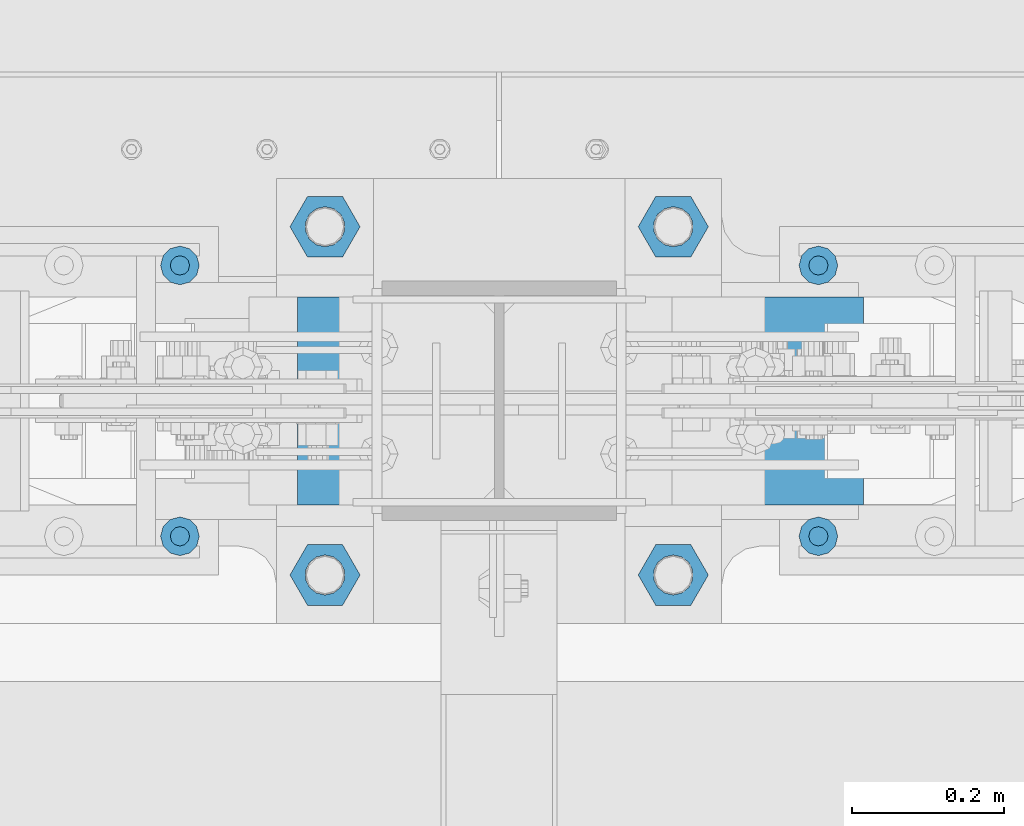
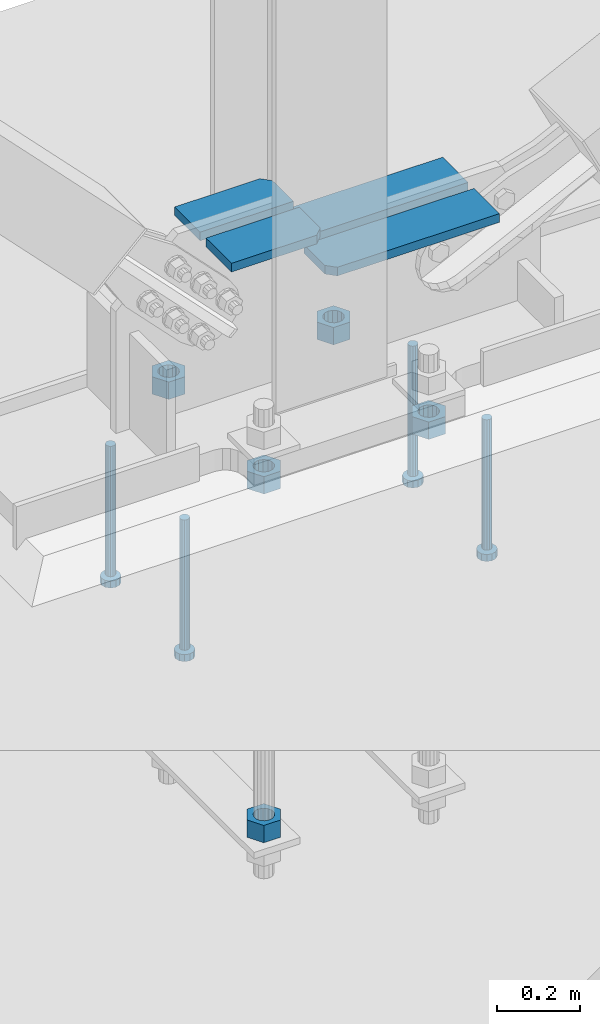
# One storey, part 886 of 1179: 13 beams, 7 elements without a shape of their own.
"""IFC2X3 building model written with IfcOpenShell, lengths in millimetres."""

from ifc_helpers import new_model, si_unit, frame, origin_with_axes, place, context, subcontext, project, spatial, faceted_brep, material, type_object, element, aggregate, save


model = new_model("IFC2X3")

# Units and contexts
model_context = context("Model", 3, precision=1e-05, world=origin_with_axes())
body_context = subcontext(model_context, "Body", "Model", "MODEL_VIEW")
ifc_project = project(units=[si_unit("LENGTHUNIT", "METRE", prefix="MILLI"), si_unit("AREAUNIT", "SQUARE_METRE"), si_unit("VOLUMEUNIT", "CUBIC_METRE"), si_unit("MASSUNIT", "GRAM", prefix="KILO"), si_unit("TIMEUNIT", "SECOND"), si_unit("PLANEANGLEUNIT", "RADIAN"), si_unit("SOLIDANGLEUNIT", "STERADIAN"), si_unit("THERMODYNAMICTEMPERATUREUNIT", "DEGREE_CELSIUS"), si_unit("LUMINOUSINTENSITYUNIT", "LUMEN")], contexts=[model_context])

# Site, building, storey
site_placement = place(None, origin_with_axes())
site = spatial("IfcSite", under=ifc_project, at=site_placement, CompositionType="ELEMENT")
building_placement = place(site_placement, origin_with_axes())
building = spatial("IfcBuilding", under=site, at=building_placement, Name="Undefined", CompositionType="ELEMENT")
storey_placement = place(building_placement, origin_with_axes())
storey = spatial("IfcBuildingStorey", under=building, at=storey_placement, Name="Undefined", CompositionType="ELEMENT", Elevation=0.0)

# Assembly, beam
assembly_1_placement = place(storey_placement, origin_with_axes())
assembly_1 = element("IfcElementAssembly", 1, at=assembly_1_placement, inside=storey, Name="PLATE", AssemblyPlace="NOTDEFINED", PredefinedType="RIGID_FRAME")
ifc_material_1 = material(Name="STEEL/A572-GR.50")
beam_type_1 = type_object("IfcBeamType", PredefinedType="NOTDEFINED")
beam_1_placement = place(assembly_1_placement, frame((8758.6086545226, 41274.2065, 143.742984862932), z_axis=(0.0, -1.0, 0.0), x_axis=(-1.0, 0.0, 0.0)))
beam_1 = element("IfcBeam", 2, at=beam_1_placement, type_object=beam_type_1, material=ifc_material_1, Name="PLATE", context=body_context, shape_type="Brep", body=[
    faceted_brep([(471.858654522599, -12.7, -38.8940000000002), (449.633654522599, -12.7, -61.1189999999988), (449.633654522599, 12.7, -61.1189999999988), (471.858654522599, 12.7, -38.8940000000002), (0.0, 12.7, -61.1189999999988), (0.0, 12.7, 61.1189999999988), (471.858654522599, 12.7, 61.1189999999988), (0.0, -12.7, 61.1189999999988), (471.858654522599, -12.7, 61.1189999999988), (0.0, -12.7, -61.1189999999988)], [[[0, 1, 2, 3]], [[4, 5, 6, 3, 2]], [[5, 7, 8, 6]], [[8, 7, 9, 1, 0]], [[9, 4, 2, 1]], [[6, 8, 0, 3]], [[9, 7, 5, 4]]]),
])
aggregate(assembly_1, [beam_1])

assembly_2_placement = place(storey_placement, origin_with_axes())
assembly_2 = element("IfcElementAssembly", 3, at=assembly_2_placement, inside=storey, Name="PLATE", AssemblyPlace="NOTDEFINED", PredefinedType="RIGID_FRAME")
beam_2_placement = place(assembly_2_placement, frame((8758.6086545226, 41123.3935, 143.742984862932), z_axis=(0.0, 1.0, 0.0), x_axis=(-1.0, 0.0, 0.0)))
beam_2 = element("IfcBeam", 4, at=beam_2_placement, type_object=beam_type_1, material=ifc_material_1, Name="PLATE", context=body_context, shape_type="Brep", body=[
    faceted_brep([(471.858654522599, -12.7, -38.8940000000002), (449.633654522599, -12.7, -61.1189999999988), (449.633654522599, 12.7, -61.1189999999988), (471.858654522599, 12.7, -38.8940000000002), (0.0, 12.7, -61.1189999999988), (0.0, 12.7, 61.1189999999988), (471.858654522599, 12.7, 61.1189999999988), (0.0, -12.7, 61.1189999999988), (471.858654522599, -12.7, 61.1189999999988), (0.0, -12.7, -61.1189999999988)], [[[0, 1, 2, 3]], [[4, 5, 6, 3, 2]], [[5, 7, 8, 6]], [[8, 7, 9, 1, 0]], [[9, 4, 2, 1]], [[6, 8, 0, 3]], [[9, 7, 5, 4]]]),
])
aggregate(assembly_2, [beam_2])

assembly_3_placement = place(storey_placement, origin_with_axes())
assembly_3 = element("IfcElementAssembly", 5, at=assembly_3_placement, inside=storey, Name="PLATE", AssemblyPlace="NOTDEFINED", PredefinedType="RIGID_FRAME")
beam_3_placement = place(assembly_3_placement, frame((8015.38676349688, 41274.2065, 258.098143425219), z_axis=(0.0, -1.0, 0.0), x_axis=(1.0, 0.0, 0.0)))
beam_3 = element("IfcBeam", 6, at=beam_3_placement, type_object=beam_type_1, material=ifc_material_1, Name="PLATE", context=body_context, shape_type="Brep", body=[
    faceted_brep([(236.438236021439, 12.7, -61.1189999999988), (258.663236021439, 12.7, -38.8940000000002), (258.663236021439, -12.7, -38.8940000000002), (236.438236021439, -12.7, -61.1189999999988), (0.0, 12.7, -61.1189999999988), (0.0, 12.7, 61.1189999999988), (258.663236021439, 12.7, 61.1189999999988), (0.0, -12.7, 61.1189999999988), (258.663236021439, -12.7, 61.1189999999988), (0.0, -12.7, -61.1189999999988)], [[[0, 1, 2, 3]], [[4, 5, 6, 1, 0]], [[5, 7, 8, 6]], [[8, 7, 9, 3, 2]], [[9, 4, 0, 3]], [[6, 8, 2, 1]], [[9, 7, 5, 4]]]),
])
aggregate(assembly_3, [beam_3])

assembly_4_placement = place(storey_placement, origin_with_axes())
assembly_4 = element("IfcElementAssembly", 7, at=assembly_4_placement, inside=storey, Name="PLATE", AssemblyPlace="NOTDEFINED", PredefinedType="RIGID_FRAME")
beam_4_placement = place(assembly_4_placement, frame((8015.38676349688, 41123.3935, 258.098143425219), z_axis=(0.0, 1.0, 0.0), x_axis=(1.0, 0.0, 0.0)))
beam_4 = element("IfcBeam", 8, at=beam_4_placement, type_object=beam_type_1, material=ifc_material_1, Name="PLATE", context=body_context, shape_type="Brep", body=[
    faceted_brep([(236.438236021439, 12.7, -61.1189999999988), (258.663236021439, 12.7, -38.8940000000002), (258.663236021439, -12.7, -38.8940000000002), (236.438236021439, -12.7, -61.1189999999988), (0.0, 12.7, -61.1189999999988), (0.0, 12.7, 61.1189999999988), (258.663236021439, 12.7, 61.1189999999988), (0.0, -12.7, 61.1189999999988), (258.663236021439, -12.7, 61.1189999999988), (0.0, -12.7, -61.1189999999988)], [[[0, 1, 2, 3]], [[4, 5, 6, 1, 0]], [[5, 7, 8, 6]], [[8, 7, 9, 3, 2]], [[9, 4, 0, 3]], [[6, 8, 2, 1]], [[9, 7, 5, 4]]]),
])
aggregate(assembly_4, [beam_4])

# Assembly, beams
assembly_5_placement = place(storey_placement, origin_with_axes())
assembly_5 = element("IfcElementAssembly", 9, at=assembly_5_placement, inside=storey, Name="TEMPLATE", AssemblyPlace="NOTDEFINED", PredefinedType="RIGID_FRAME")
ifc_material_2 = material(Name="STEEL/A36")
beam_type_2 = type_object("IfcBeamType", Name="2_HEAVY_HEX_NUT", PredefinedType="NOTDEFINED")
beam_5_placement = place(assembly_5_placement, frame((8051.79998779297, 40970.2, -279.4), z_axis=(0.0, -1.0, 0.0), x_axis=(0.0, 0.0, -1.0)))
beam_5 = element("IfcBeam", 10, at=beam_5_placement, type_object=beam_type_2, material=ifc_material_2, Name="NUT", ObjectType="2_HEAVY_HEX_NUT", context=body_context, shape_type="Brep", body=[
    faceted_brep([(0.0, -46.0369987487793, 9.09494701772928e-13), (0.0, -23.0184993743896, -39.869213104248), (50.7999999999993, -23.0184993743896, -39.869213104248), (50.7999999999993, -46.0369987487793, 9.09494701772928e-13), (0.0, 23.0184993743896, -39.869213104248), (50.7999999999993, 23.0184993743896, -39.869213104248), (0.0, 46.0369987487793, -9.09494701772928e-13), (50.7999999999993, 46.0369987487793, -9.09494701772928e-13), (0.0, 23.0184993743896, 39.869213104248), (50.7999999999993, 23.0184993743896, 39.869213104248), (0.0, -23.0184993743896, 39.869213104248), (50.7999999999993, -23.0184993743896, 39.869213104248), (0.0, 0.0, 26.1940002441406), (0.0, 11.3650617044477, 23.5999013092769), (50.7999999999993, 11.3650617044477, 23.5999013092769), (50.7999999999993, 0.0, 26.1940002441406), (0.0, 20.4791109456419, 16.3316083006703), (50.7999999999993, 20.4791109456419, 16.3316083006703), (0.0, 25.5370200498364, 5.82867859874477), (50.7999999999993, 25.5370200498364, 5.82867859874477), (0.0, 25.5370200498364, -5.82867859874477), (50.7999999999993, 25.5370200498364, -5.82867859874477), (0.0, 20.4791109456419, -16.3316083006703), (50.7999999999993, 20.4791109456419, -16.3316083006703), (0.0, 11.365061704455, -23.5999013092769), (50.7999999999993, 11.365061704455, -23.5999013092769), (0.0, 0.0, -26.1940002441406), (50.7999999999993, 0.0, -26.1940002441406), (0.0, -11.3650617044477, -23.5999013092769), (50.7999999999993, -11.3650617044477, -23.5999013092769), (0.0, -20.4791109456419, -16.3316083006703), (50.7999999999993, -20.4791109456419, -16.3316083006703), (0.0, -25.5370200498364, -5.82867859874477), (50.7999999999993, -25.5370200498364, -5.82867859874477), (0.0, -25.5370200498364, 5.82867859874477), (50.7999999999993, -25.5370200498364, 5.82867859874477), (0.0, -20.4791109456419, 16.3316083006703), (50.7999999999993, -20.4791109456419, 16.3316083006703), (0.0, -11.365061704455, 23.5999013092769), (50.7999999999993, -11.365061704455, 23.5999013092769)], [[[0, 1, 2, 3]], [[1, 4, 5, 2]], [[4, 6, 7, 5]], [[6, 8, 9, 7]], [[8, 10, 11, 9]], [[10, 0, 3, 11]], [[12, 13, 14, 15]], [[13, 16, 17, 14]], [[16, 18, 19, 17]], [[18, 20, 21, 19]], [[20, 22, 23, 21]], [[22, 24, 25, 23]], [[24, 26, 27, 25]], [[26, 28, 29, 27]], [[28, 30, 31, 29]], [[30, 32, 33, 31]], [[32, 34, 35, 33]], [[34, 36, 37, 35]], [[36, 38, 39, 37]], [[38, 12, 15, 39]], [[5, 7, 9, 11, 3, 2], [17, 19, 21, 23, 25, 27, 29, 31, 33, 35, 37, 39, 15, 14]], [[10, 8, 6, 4, 1, 0], [38, 36, 34, 32, 30, 28, 26, 24, 22, 20, 18, 16, 13, 12]]]),
])
beam_6_placement = place(assembly_5_placement, frame((8508.99998779298, 40970.2, -279.4), z_axis=(0.0, 1.0, 0.0), x_axis=(0.0, 0.0, -1.0)))
beam_6 = element("IfcBeam", 11, at=beam_6_placement, type_object=beam_type_2, material=ifc_material_2, Name="NUT", ObjectType="2_HEAVY_HEX_NUT", context=body_context, shape_type="Brep", body=[
    faceted_brep([(0.0, -46.0369987487793, 9.09494701772928e-13), (0.0, -23.0184993743896, -39.869213104248), (50.7999999999993, -23.0184993743896, -39.869213104248), (50.7999999999993, -46.0369987487793, 9.09494701772928e-13), (0.0, 23.0184993743896, -39.869213104248), (50.7999999999993, 23.0184993743896, -39.869213104248), (0.0, 46.0369987487793, -9.09494701772928e-13), (50.7999999999993, 46.0369987487793, -9.09494701772928e-13), (0.0, 23.0184993743896, 39.869213104248), (50.7999999999993, 23.0184993743896, 39.869213104248), (0.0, -23.0184993743896, 39.869213104248), (50.7999999999993, -23.0184993743896, 39.869213104248), (0.0, 0.0, 26.1940002441406), (0.0, 11.3650617044477, 23.5999013092769), (50.7999999999993, 11.3650617044477, 23.5999013092769), (50.7999999999993, 0.0, 26.1940002441406), (0.0, 20.4791109456419, 16.3316083006703), (50.7999999999993, 20.4791109456419, 16.3316083006703), (0.0, 25.5370200498364, 5.82867859874477), (50.7999999999993, 25.5370200498364, 5.82867859874477), (0.0, 25.5370200498364, -5.82867859874477), (50.7999999999993, 25.5370200498364, -5.82867859874477), (0.0, 20.4791109456419, -16.3316083006703), (50.7999999999993, 20.4791109456419, -16.3316083006703), (0.0, 11.365061704455, -23.5999013092769), (50.7999999999993, 11.365061704455, -23.5999013092769), (0.0, 0.0, -26.1940002441406), (50.7999999999993, 0.0, -26.1940002441406), (0.0, -11.3650617044477, -23.5999013092769), (50.7999999999993, -11.3650617044477, -23.5999013092769), (0.0, -20.4791109456419, -16.3316083006703), (50.7999999999993, -20.4791109456419, -16.3316083006703), (0.0, -25.5370200498364, -5.82867859874477), (50.7999999999993, -25.5370200498364, -5.82867859874477), (0.0, -25.5370200498364, 5.82867859874477), (50.7999999999993, -25.5370200498364, 5.82867859874477), (0.0, -20.4791109456419, 16.3316083006703), (50.7999999999993, -20.4791109456419, 16.3316083006703), (0.0, -11.365061704455, 23.5999013092769), (50.7999999999993, -11.365061704455, 23.5999013092769)], [[[0, 1, 2, 3]], [[1, 4, 5, 2]], [[4, 6, 7, 5]], [[6, 8, 9, 7]], [[8, 10, 11, 9]], [[10, 0, 3, 11]], [[12, 13, 14, 15]], [[13, 16, 17, 14]], [[16, 18, 19, 17]], [[18, 20, 21, 19]], [[20, 22, 23, 21]], [[22, 24, 25, 23]], [[24, 26, 27, 25]], [[26, 28, 29, 27]], [[28, 30, 31, 29]], [[30, 32, 33, 31]], [[32, 34, 35, 33]], [[34, 36, 37, 35]], [[36, 38, 39, 37]], [[38, 12, 15, 39]], [[5, 7, 9, 11, 3, 2], [17, 19, 21, 23, 25, 27, 29, 31, 33, 35, 37, 39, 15, 14]], [[10, 8, 6, 4, 1, 0], [38, 36, 34, 32, 30, 28, 26, 24, 22, 20, 18, 16, 13, 12]]]),
])
beam_7_placement = place(assembly_5_placement, frame((8051.79998779297, 41427.4, -279.4), z_axis=(0.0, -1.0, 0.0), x_axis=(0.0, 0.0, -1.0)))
beam_7 = element("IfcBeam", 12, at=beam_7_placement, type_object=beam_type_2, material=ifc_material_2, Name="NUT", ObjectType="2_HEAVY_HEX_NUT", context=body_context, shape_type="Brep", body=[
    faceted_brep([(0.0, -46.0369987487793, 9.09494701772928e-13), (0.0, -23.0184993743896, -39.869213104248), (50.7999999999993, -23.0184993743896, -39.869213104248), (50.7999999999993, -46.0369987487793, 9.09494701772928e-13), (0.0, 23.0184993743896, -39.869213104248), (50.7999999999993, 23.0184993743896, -39.869213104248), (0.0, 46.0369987487793, -9.09494701772928e-13), (50.7999999999993, 46.0369987487793, -9.09494701772928e-13), (0.0, 23.0184993743896, 39.869213104248), (50.7999999999993, 23.0184993743896, 39.869213104248), (0.0, -23.0184993743896, 39.869213104248), (50.7999999999993, -23.0184993743896, 39.869213104248), (0.0, 0.0, 26.1940002441406), (0.0, 11.3650617044477, 23.5999013092769), (50.7999999999993, 11.3650617044477, 23.5999013092769), (50.7999999999993, 0.0, 26.1940002441406), (0.0, 20.4791109456419, 16.3316083006703), (50.7999999999993, 20.4791109456419, 16.3316083006703), (0.0, 25.5370200498364, 5.82867859874477), (50.7999999999993, 25.5370200498364, 5.82867859874477), (0.0, 25.5370200498364, -5.82867859874477), (50.7999999999993, 25.5370200498364, -5.82867859874477), (0.0, 20.4791109456419, -16.3316083006703), (50.7999999999993, 20.4791109456419, -16.3316083006703), (0.0, 11.365061704455, -23.5999013092769), (50.7999999999993, 11.365061704455, -23.5999013092769), (0.0, 0.0, -26.1940002441406), (50.7999999999993, 0.0, -26.1940002441406), (0.0, -11.3650617044477, -23.5999013092769), (50.7999999999993, -11.3650617044477, -23.5999013092769), (0.0, -20.4791109456419, -16.3316083006703), (50.7999999999993, -20.4791109456419, -16.3316083006703), (0.0, -25.5370200498364, -5.82867859874477), (50.7999999999993, -25.5370200498364, -5.82867859874477), (0.0, -25.5370200498364, 5.82867859874477), (50.7999999999993, -25.5370200498364, 5.82867859874477), (0.0, -20.4791109456419, 16.3316083006703), (50.7999999999993, -20.4791109456419, 16.3316083006703), (0.0, -11.365061704455, 23.5999013092769), (50.7999999999993, -11.365061704455, 23.5999013092769)], [[[0, 1, 2, 3]], [[1, 4, 5, 2]], [[4, 6, 7, 5]], [[6, 8, 9, 7]], [[8, 10, 11, 9]], [[10, 0, 3, 11]], [[12, 13, 14, 15]], [[13, 16, 17, 14]], [[16, 18, 19, 17]], [[18, 20, 21, 19]], [[20, 22, 23, 21]], [[22, 24, 25, 23]], [[24, 26, 27, 25]], [[26, 28, 29, 27]], [[28, 30, 31, 29]], [[30, 32, 33, 31]], [[32, 34, 35, 33]], [[34, 36, 37, 35]], [[36, 38, 39, 37]], [[38, 12, 15, 39]], [[5, 7, 9, 11, 3, 2], [17, 19, 21, 23, 25, 27, 29, 31, 33, 35, 37, 39, 15, 14]], [[10, 8, 6, 4, 1, 0], [38, 36, 34, 32, 30, 28, 26, 24, 22, 20, 18, 16, 13, 12]]]),
])
beam_8_placement = place(assembly_5_placement, frame((8508.99998779298, 41427.4, -279.4), z_axis=(0.0, 1.0, 0.0), x_axis=(0.0, 0.0, -1.0)))
beam_8 = element("IfcBeam", 13, at=beam_8_placement, type_object=beam_type_2, material=ifc_material_2, Name="NUT", ObjectType="2_HEAVY_HEX_NUT", context=body_context, shape_type="Brep", body=[
    faceted_brep([(0.0, -46.0369987487793, 9.09494701772928e-13), (0.0, -23.0184993743896, -39.869213104248), (50.7999999999993, -23.0184993743896, -39.869213104248), (50.7999999999993, -46.0369987487793, 9.09494701772928e-13), (0.0, 23.0184993743896, -39.869213104248), (50.7999999999993, 23.0184993743896, -39.869213104248), (0.0, 46.0369987487793, -9.09494701772928e-13), (50.7999999999993, 46.0369987487793, -9.09494701772928e-13), (0.0, 23.0184993743896, 39.869213104248), (50.7999999999993, 23.0184993743896, 39.869213104248), (0.0, -23.0184993743896, 39.869213104248), (50.7999999999993, -23.0184993743896, 39.869213104248), (0.0, 0.0, 26.1940002441406), (0.0, 11.3650617044477, 23.5999013092769), (50.7999999999993, 11.3650617044477, 23.5999013092769), (50.7999999999993, 0.0, 26.1940002441406), (0.0, 20.4791109456419, 16.3316083006703), (50.7999999999993, 20.4791109456419, 16.3316083006703), (0.0, 25.5370200498364, 5.82867859874477), (50.7999999999993, 25.5370200498364, 5.82867859874477), (0.0, 25.5370200498364, -5.82867859874477), (50.7999999999993, 25.5370200498364, -5.82867859874477), (0.0, 20.4791109456419, -16.3316083006703), (50.7999999999993, 20.4791109456419, -16.3316083006703), (0.0, 11.365061704455, -23.5999013092769), (50.7999999999993, 11.365061704455, -23.5999013092769), (0.0, 0.0, -26.1940002441406), (50.7999999999993, 0.0, -26.1940002441406), (0.0, -11.3650617044477, -23.5999013092769), (50.7999999999993, -11.3650617044477, -23.5999013092769), (0.0, -20.4791109456419, -16.3316083006703), (50.7999999999993, -20.4791109456419, -16.3316083006703), (0.0, -25.5370200498364, -5.82867859874477), (50.7999999999993, -25.5370200498364, -5.82867859874477), (0.0, -25.5370200498364, 5.82867859874477), (50.7999999999993, -25.5370200498364, 5.82867859874477), (0.0, -20.4791109456419, 16.3316083006703), (50.7999999999993, -20.4791109456419, 16.3316083006703), (0.0, -11.365061704455, 23.5999013092769), (50.7999999999993, -11.365061704455, 23.5999013092769)], [[[0, 1, 2, 3]], [[1, 4, 5, 2]], [[4, 6, 7, 5]], [[6, 8, 9, 7]], [[8, 10, 11, 9]], [[10, 0, 3, 11]], [[12, 13, 14, 15]], [[13, 16, 17, 14]], [[16, 18, 19, 17]], [[18, 20, 21, 19]], [[20, 22, 23, 21]], [[22, 24, 25, 23]], [[24, 26, 27, 25]], [[26, 28, 29, 27]], [[28, 30, 31, 29]], [[30, 32, 33, 31]], [[32, 34, 35, 33]], [[34, 36, 37, 35]], [[36, 38, 39, 37]], [[38, 12, 15, 39]], [[5, 7, 9, 11, 3, 2], [17, 19, 21, 23, 25, 27, 29, 31, 33, 35, 37, 39, 15, 14]], [[10, 8, 6, 4, 1, 0], [38, 36, 34, 32, 30, 28, 26, 24, 22, 20, 18, 16, 13, 12]]]),
])
beam_9_placement = place(assembly_5_placement, frame((8051.80000000002, 40970.2, -1301.75), z_axis=(0.0, -1.0, 0.0), x_axis=(0.0, 0.0, -1.0)))
beam_9 = element("IfcBeam", 14, at=beam_9_placement, type_object=beam_type_2, material=ifc_material_2, Name="NUT", ObjectType="2_HEAVY_HEX_NUT", context=body_context, shape_type="Brep", body=[
    faceted_brep([(0.0, -46.0369987487793, 9.09494701772928e-13), (0.0, -23.0184993743896, -39.869213104248), (50.7999999999993, -23.0184993743896, -39.869213104248), (50.7999999999993, -46.0369987487793, 9.09494701772928e-13), (0.0, 23.0184993743896, -39.869213104248), (50.7999999999993, 23.0184993743896, -39.869213104248), (0.0, 46.0369987487793, -9.09494701772928e-13), (50.7999999999993, 46.0369987487793, -9.09494701772928e-13), (0.0, 23.0184993743896, 39.869213104248), (50.7999999999993, 23.0184993743896, 39.869213104248), (0.0, -23.0184993743896, 39.869213104248), (50.7999999999993, -23.0184993743896, 39.869213104248), (0.0, 0.0, 26.1940002441406), (0.0, 11.3650617044477, 23.5999013092769), (50.7999999999993, 11.3650617044477, 23.5999013092769), (50.7999999999993, 0.0, 26.1940002441406), (0.0, 20.4791109456419, 16.3316083006703), (50.7999999999993, 20.4791109456419, 16.3316083006703), (0.0, 25.5370200498364, 5.82867859874477), (50.7999999999993, 25.5370200498364, 5.82867859874477), (0.0, 25.5370200498364, -5.82867859874477), (50.7999999999993, 25.5370200498364, -5.82867859874477), (0.0, 20.4791109456419, -16.3316083006703), (50.7999999999993, 20.4791109456419, -16.3316083006703), (0.0, 11.365061704455, -23.5999013092769), (50.7999999999993, 11.365061704455, -23.5999013092769), (0.0, 0.0, -26.1940002441406), (50.7999999999993, 0.0, -26.1940002441406), (0.0, -11.3650617044477, -23.5999013092769), (50.7999999999993, -11.3650617044477, -23.5999013092769), (0.0, -20.4791109456419, -16.3316083006703), (50.7999999999993, -20.4791109456419, -16.3316083006703), (0.0, -25.5370200498364, -5.82867859874477), (50.7999999999993, -25.5370200498364, -5.82867859874477), (0.0, -25.5370200498364, 5.82867859874477), (50.7999999999993, -25.5370200498364, 5.82867859874477), (0.0, -20.4791109456419, 16.3316083006703), (50.7999999999993, -20.4791109456419, 16.3316083006703), (0.0, -11.365061704455, 23.5999013092769), (50.7999999999993, -11.365061704455, 23.5999013092769)], [[[0, 1, 2, 3]], [[1, 4, 5, 2]], [[4, 6, 7, 5]], [[6, 8, 9, 7]], [[8, 10, 11, 9]], [[10, 0, 3, 11]], [[12, 13, 14, 15]], [[13, 16, 17, 14]], [[16, 18, 19, 17]], [[18, 20, 21, 19]], [[20, 22, 23, 21]], [[22, 24, 25, 23]], [[24, 26, 27, 25]], [[26, 28, 29, 27]], [[28, 30, 31, 29]], [[30, 32, 33, 31]], [[32, 34, 35, 33]], [[34, 36, 37, 35]], [[36, 38, 39, 37]], [[38, 12, 15, 39]], [[5, 7, 9, 11, 3, 2], [17, 19, 21, 23, 25, 27, 29, 31, 33, 35, 37, 39, 15, 14]], [[10, 8, 6, 4, 1, 0], [38, 36, 34, 32, 30, 28, 26, 24, 22, 20, 18, 16, 13, 12]]]),
])
aggregate(assembly_5, [beam_5, beam_6, beam_7, beam_8, beam_9])

assembly_6_placement = place(storey_placement, origin_with_axes())
assembly_6 = element("IfcElementAssembly", 15, at=assembly_6_placement, inside=storey, Name="EMBED_PLATE", AssemblyPlace="NOTDEFINED", PredefinedType="RIGID_FRAME")
ifc_material_3 = material(Name="STEEL/A108")
beam_type_3 = type_object("IfcBeamType", Name="STUD_1-DIA", PredefinedType="NOTDEFINED")
beam_10_placement = place(assembly_6_placement, frame((8699.5, 41376.6, -393.7), z_axis=(1.0, 0.0, 0.0), x_axis=(0.0, 0.0, -1.0)))
beam_10 = element("IfcBeam", 16, at=beam_10_placement, type_object=beam_type_3, material=ifc_material_3, Name="STUD", ObjectType="STUD_1-DIA", context=body_context, shape_type="Brep", body=[
    faceted_brep([(0.0, -12.7, 0.0), (0.0, -11.0, -6.34999990463257), (382.016, -11.0, -6.34999990463257), (382.016, -12.6999998092651, 0.0), (0.0, -6.34999990463257, -11.0), (382.016, -6.34999990463257, -11.0), (0.0, 0.0, -12.6999998092651), (382.016, 0.0, -12.6999998092651), (0.0, 6.34999990463257, -11.0), (382.016, 6.34999990463257, -11.0), (0.0, 11.0, -6.34999990463257), (382.016, 11.0, -6.34999990463257), (0.0, 12.7, 0.0), (382.016, 12.6999998092651, 0.0), (0.0, 11.0, 6.34999990463257), (382.016, 11.0, 6.34999990463257), (0.0, 6.34999990463257, 11.0), (382.016, 6.34999990463257, 11.0), (0.0, 0.0, 12.6999998092651), (382.016, 0.0, 12.6999998092651), (0.0, -6.34999990463257, 11.0), (382.016, -6.34999990463257, 11.0), (0.0, -11.0, 6.34999990463257), (382.016, -11.0, 6.34999990463257), (386.08, -22.0, -12.6999998092651), (386.08, -25.3999996185303, 0.0), (386.08, -12.6999998092651, -22.0), (386.08, 0.0, -25.3999996185303), (386.08, 12.6999998092651, -22.0), (386.08, 22.0, -12.6999998092651), (386.08, 25.3999996185303, 0.0), (386.08, 22.0, 12.6999998092651), (386.08, 12.6999998092651, 22.0), (386.08, 0.0, 25.3999996185303), (386.08, -12.6999998092651, 22.0), (386.08, -22.0, 12.6999998092651), (406.4, -22.0, -12.6999998092651), (406.4, -25.3999996185303, 0.0), (406.4, -12.6999998092651, -22.0), (406.4, 0.0, -25.3999996185303), (406.4, 12.6999998092651, -22.0), (406.4, 22.0, -12.6999998092651), (406.4, 25.3999996185303, 0.0), (406.4, 22.0, 12.6999998092651), (406.4, 12.6999998092651, 22.0), (406.4, 0.0, 25.3999996185303), (406.4, -12.6999998092651, 22.0), (406.4, -22.0, 12.6999998092651)], [[[0, 1, 2, 3]], [[1, 4, 5, 2]], [[4, 6, 7, 5]], [[6, 8, 9, 7]], [[8, 10, 11, 9]], [[10, 12, 13, 11]], [[12, 14, 15, 13]], [[14, 16, 17, 15]], [[16, 18, 19, 17]], [[18, 20, 21, 19]], [[20, 22, 23, 21]], [[22, 0, 3, 23]], [[22, 20, 18, 16, 14, 12, 10, 8, 6, 4, 1, 0]], [[3, 2, 24, 25]], [[2, 5, 26, 24]], [[5, 7, 27, 26]], [[7, 9, 28, 27]], [[9, 11, 29, 28]], [[11, 13, 30, 29]], [[13, 15, 31, 30]], [[15, 17, 32, 31]], [[17, 19, 33, 32]], [[19, 21, 34, 33]], [[21, 23, 35, 34]], [[23, 3, 25, 35]], [[25, 24, 36, 37]], [[24, 26, 38, 36]], [[26, 27, 39, 38]], [[27, 28, 40, 39]], [[28, 29, 41, 40]], [[29, 30, 42, 41]], [[30, 31, 43, 42]], [[31, 32, 44, 43]], [[32, 33, 45, 44]], [[33, 34, 46, 45]], [[34, 35, 47, 46]], [[35, 25, 37, 47]], [[38, 39, 40, 41, 42, 43, 44, 45, 46, 47, 37, 36]]]),
])
beam_11_placement = place(assembly_6_placement, frame((8699.5, 41021.0, -393.7), z_axis=(1.0, 0.0, 0.0), x_axis=(0.0, 0.0, -1.0)))
beam_11 = element("IfcBeam", 17, at=beam_11_placement, type_object=beam_type_3, material=ifc_material_3, Name="STUD", ObjectType="STUD_1-DIA", context=body_context, shape_type="Brep", body=[
    faceted_brep([(0.0, -12.7, 0.0), (0.0, -11.0, -6.34999990463257), (382.016, -11.0, -6.34999990463257), (382.016, -12.6999998092651, 0.0), (0.0, -6.34999990463257, -11.0), (382.016, -6.34999990463257, -11.0), (0.0, 0.0, -12.6999998092651), (382.016, 0.0, -12.6999998092651), (0.0, 6.34999990463257, -11.0), (382.016, 6.34999990463257, -11.0), (0.0, 11.0, -6.34999990463257), (382.016, 11.0, -6.34999990463257), (0.0, 12.7, 0.0), (382.016, 12.6999998092651, 0.0), (0.0, 11.0, 6.34999990463257), (382.016, 11.0, 6.34999990463257), (0.0, 6.34999990463257, 11.0), (382.016, 6.34999990463257, 11.0), (0.0, 0.0, 12.6999998092651), (382.016, 0.0, 12.6999998092651), (0.0, -6.34999990463257, 11.0), (382.016, -6.34999990463257, 11.0), (0.0, -11.0, 6.34999990463257), (382.016, -11.0, 6.34999990463257), (386.08, -22.0, -12.6999998092651), (386.08, -25.3999996185303, 0.0), (386.08, -12.6999998092651, -22.0), (386.08, 0.0, -25.3999996185303), (386.08, 12.6999998092651, -22.0), (386.08, 22.0, -12.6999998092651), (386.08, 25.3999996185303, 0.0), (386.08, 22.0, 12.6999998092651), (386.08, 12.6999998092651, 22.0), (386.08, 0.0, 25.3999996185303), (386.08, -12.6999998092651, 22.0), (386.08, -22.0, 12.6999998092651), (406.4, -22.0, -12.6999998092651), (406.4, -25.3999996185303, 0.0), (406.4, -12.6999998092651, -22.0), (406.4, 0.0, -25.3999996185303), (406.4, 12.6999998092651, -22.0), (406.4, 22.0, -12.6999998092651), (406.4, 25.3999996185303, 0.0), (406.4, 22.0, 12.6999998092651), (406.4, 12.6999998092651, 22.0), (406.4, 0.0, 25.3999996185303), (406.4, -12.6999998092651, 22.0), (406.4, -22.0, 12.6999998092651)], [[[0, 1, 2, 3]], [[1, 4, 5, 2]], [[4, 6, 7, 5]], [[6, 8, 9, 7]], [[8, 10, 11, 9]], [[10, 12, 13, 11]], [[12, 14, 15, 13]], [[14, 16, 17, 15]], [[16, 18, 19, 17]], [[18, 20, 21, 19]], [[20, 22, 23, 21]], [[22, 0, 3, 23]], [[22, 20, 18, 16, 14, 12, 10, 8, 6, 4, 1, 0]], [[3, 2, 24, 25]], [[2, 5, 26, 24]], [[5, 7, 27, 26]], [[7, 9, 28, 27]], [[9, 11, 29, 28]], [[11, 13, 30, 29]], [[13, 15, 31, 30]], [[15, 17, 32, 31]], [[17, 19, 33, 32]], [[19, 21, 34, 33]], [[21, 23, 35, 34]], [[23, 3, 25, 35]], [[25, 24, 36, 37]], [[24, 26, 38, 36]], [[26, 27, 39, 38]], [[27, 28, 40, 39]], [[28, 29, 41, 40]], [[29, 30, 42, 41]], [[30, 31, 43, 42]], [[31, 32, 44, 43]], [[32, 33, 45, 44]], [[33, 34, 46, 45]], [[34, 35, 47, 46]], [[35, 25, 37, 47]], [[38, 39, 40, 41, 42, 43, 44, 45, 46, 47, 37, 36]]]),
])
aggregate(assembly_6, [beam_10, beam_11])

assembly_7_placement = place(storey_placement, origin_with_axes())
assembly_7 = element("IfcElementAssembly", 18, at=assembly_7_placement, inside=storey, Name="EMBED_PLATE", AssemblyPlace="NOTDEFINED", PredefinedType="RIGID_FRAME")
beam_12_placement = place(assembly_7_placement, frame((7861.30000000002, 41376.6, -393.7), z_axis=(1.0, 0.0, 0.0), x_axis=(0.0, 0.0, -1.0)))
beam_12 = element("IfcBeam", 19, at=beam_12_placement, type_object=beam_type_3, material=ifc_material_3, Name="STUD", ObjectType="STUD_1-DIA", context=body_context, shape_type="Brep", body=[
    faceted_brep([(0.0, -12.7, 0.0), (0.0, -11.0, -6.34999990463257), (382.016, -11.0, -6.34999990463257), (382.016, -12.6999998092651, 0.0), (0.0, -6.34999990463257, -11.0), (382.016, -6.34999990463257, -11.0), (0.0, 0.0, -12.6999998092651), (382.016, 0.0, -12.6999998092651), (0.0, 6.34999990463257, -11.0), (382.016, 6.34999990463257, -11.0), (0.0, 11.0, -6.34999990463257), (382.016, 11.0, -6.34999990463257), (0.0, 12.7, 0.0), (382.016, 12.6999998092651, 0.0), (0.0, 11.0, 6.34999990463257), (382.016, 11.0, 6.34999990463257), (0.0, 6.34999990463257, 11.0), (382.016, 6.34999990463257, 11.0), (0.0, 0.0, 12.6999998092651), (382.016, 0.0, 12.6999998092651), (0.0, -6.34999990463257, 11.0), (382.016, -6.34999990463257, 11.0), (0.0, -11.0, 6.34999990463257), (382.016, -11.0, 6.34999990463257), (386.08, -22.0, -12.6999998092651), (386.08, -25.3999996185303, 0.0), (386.08, -12.6999998092651, -22.0), (386.08, 0.0, -25.3999996185303), (386.08, 12.6999998092651, -22.0), (386.08, 22.0, -12.6999998092651), (386.08, 25.3999996185303, 0.0), (386.08, 22.0, 12.6999998092651), (386.08, 12.6999998092651, 22.0), (386.08, 0.0, 25.3999996185303), (386.08, -12.6999998092651, 22.0), (386.08, -22.0, 12.6999998092651), (406.4, -22.0, -12.6999998092651), (406.4, -25.3999996185303, 0.0), (406.4, -12.6999998092651, -22.0), (406.4, 0.0, -25.3999996185303), (406.4, 12.6999998092651, -22.0), (406.4, 22.0, -12.6999998092651), (406.4, 25.3999996185303, 0.0), (406.4, 22.0, 12.6999998092651), (406.4, 12.6999998092651, 22.0), (406.4, 0.0, 25.3999996185303), (406.4, -12.6999998092651, 22.0), (406.4, -22.0, 12.6999998092651)], [[[0, 1, 2, 3]], [[1, 4, 5, 2]], [[4, 6, 7, 5]], [[6, 8, 9, 7]], [[8, 10, 11, 9]], [[10, 12, 13, 11]], [[12, 14, 15, 13]], [[14, 16, 17, 15]], [[16, 18, 19, 17]], [[18, 20, 21, 19]], [[20, 22, 23, 21]], [[22, 0, 3, 23]], [[22, 20, 18, 16, 14, 12, 10, 8, 6, 4, 1, 0]], [[3, 2, 24, 25]], [[2, 5, 26, 24]], [[5, 7, 27, 26]], [[7, 9, 28, 27]], [[9, 11, 29, 28]], [[11, 13, 30, 29]], [[13, 15, 31, 30]], [[15, 17, 32, 31]], [[17, 19, 33, 32]], [[19, 21, 34, 33]], [[21, 23, 35, 34]], [[23, 3, 25, 35]], [[25, 24, 36, 37]], [[24, 26, 38, 36]], [[26, 27, 39, 38]], [[27, 28, 40, 39]], [[28, 29, 41, 40]], [[29, 30, 42, 41]], [[30, 31, 43, 42]], [[31, 32, 44, 43]], [[32, 33, 45, 44]], [[33, 34, 46, 45]], [[34, 35, 47, 46]], [[35, 25, 37, 47]], [[38, 39, 40, 41, 42, 43, 44, 45, 46, 47, 37, 36]]]),
])
beam_13_placement = place(assembly_7_placement, frame((7861.30000000002, 41021.0, -393.7), z_axis=(1.0, 0.0, 0.0), x_axis=(0.0, 0.0, -1.0)))
beam_13 = element("IfcBeam", 20, at=beam_13_placement, type_object=beam_type_3, material=ifc_material_3, Name="STUD", ObjectType="STUD_1-DIA", context=body_context, shape_type="Brep", body=[
    faceted_brep([(0.0, -12.7, 0.0), (0.0, -11.0, -6.34999990463257), (382.016, -11.0, -6.34999990463257), (382.016, -12.6999998092651, 0.0), (0.0, -6.34999990463257, -11.0), (382.016, -6.34999990463257, -11.0), (0.0, 0.0, -12.6999998092651), (382.016, 0.0, -12.6999998092651), (0.0, 6.34999990463257, -11.0), (382.016, 6.34999990463257, -11.0), (0.0, 11.0, -6.34999990463257), (382.016, 11.0, -6.34999990463257), (0.0, 12.7, 0.0), (382.016, 12.6999998092651, 0.0), (0.0, 11.0, 6.34999990463257), (382.016, 11.0, 6.34999990463257), (0.0, 6.34999990463257, 11.0), (382.016, 6.34999990463257, 11.0), (0.0, 0.0, 12.6999998092651), (382.016, 0.0, 12.6999998092651), (0.0, -6.34999990463257, 11.0), (382.016, -6.34999990463257, 11.0), (0.0, -11.0, 6.34999990463257), (382.016, -11.0, 6.34999990463257), (386.08, -22.0, -12.6999998092651), (386.08, -25.3999996185303, 0.0), (386.08, -12.6999998092651, -22.0), (386.08, 0.0, -25.3999996185303), (386.08, 12.6999998092651, -22.0), (386.08, 22.0, -12.6999998092651), (386.08, 25.3999996185303, 0.0), (386.08, 22.0, 12.6999998092651), (386.08, 12.6999998092651, 22.0), (386.08, 0.0, 25.3999996185303), (386.08, -12.6999998092651, 22.0), (386.08, -22.0, 12.6999998092651), (406.4, -22.0, -12.6999998092651), (406.4, -25.3999996185303, 0.0), (406.4, -12.6999998092651, -22.0), (406.4, 0.0, -25.3999996185303), (406.4, 12.6999998092651, -22.0), (406.4, 22.0, -12.6999998092651), (406.4, 25.3999996185303, 0.0), (406.4, 22.0, 12.6999998092651), (406.4, 12.6999998092651, 22.0), (406.4, 0.0, 25.3999996185303), (406.4, -12.6999998092651, 22.0), (406.4, -22.0, 12.6999998092651)], [[[0, 1, 2, 3]], [[1, 4, 5, 2]], [[4, 6, 7, 5]], [[6, 8, 9, 7]], [[8, 10, 11, 9]], [[10, 12, 13, 11]], [[12, 14, 15, 13]], [[14, 16, 17, 15]], [[16, 18, 19, 17]], [[18, 20, 21, 19]], [[20, 22, 23, 21]], [[22, 0, 3, 23]], [[22, 20, 18, 16, 14, 12, 10, 8, 6, 4, 1, 0]], [[3, 2, 24, 25]], [[2, 5, 26, 24]], [[5, 7, 27, 26]], [[7, 9, 28, 27]], [[9, 11, 29, 28]], [[11, 13, 30, 29]], [[13, 15, 31, 30]], [[15, 17, 32, 31]], [[17, 19, 33, 32]], [[19, 21, 34, 33]], [[21, 23, 35, 34]], [[23, 3, 25, 35]], [[25, 24, 36, 37]], [[24, 26, 38, 36]], [[26, 27, 39, 38]], [[27, 28, 40, 39]], [[28, 29, 41, 40]], [[29, 30, 42, 41]], [[30, 31, 43, 42]], [[31, 32, 44, 43]], [[32, 33, 45, 44]], [[33, 34, 46, 45]], [[34, 35, 47, 46]], [[35, 25, 37, 47]], [[38, 39, 40, 41, 42, 43, 44, 45, 46, 47, 37, 36]]]),
])
aggregate(assembly_7, [beam_12, beam_13])

save(model, "model.ifc")
